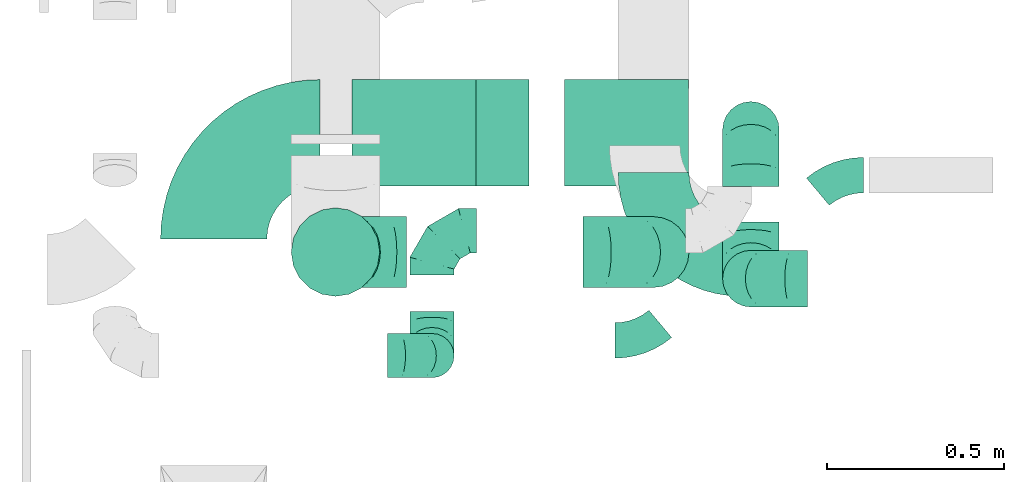
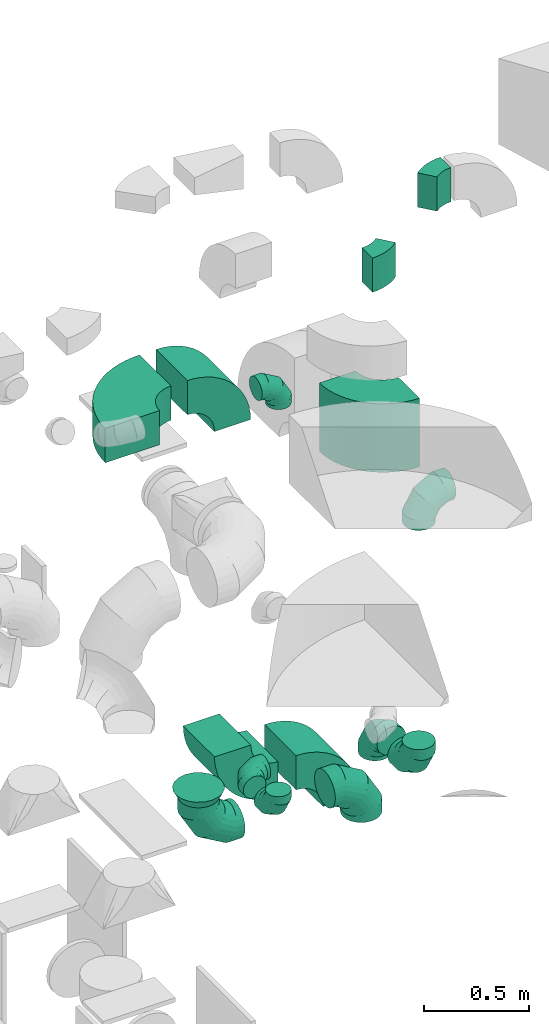
# One storey, part 30 of 59: 16 flow fittings.
"""IFC2X3 building model written with IfcOpenShell, lengths in millimetres."""

from ifc_helpers import new_model, entity, si_unit, converted_unit, derived_unit, direction, frame, frame_2d, origin, place, context, subcontext, project, spatial, polyline, circle_curve, parameter, trimmed, segment, composite_curve, outline, extrude, faceted_brep, source, transform, mapped, material, type_object, type_shapes, element, save


model = new_model("IFC2X3")

# Units and contexts
model_context = context("Model", 3, precision=0.01, world=origin(), true_north=direction((6.12303176911189e-17, 1.0)))
body_context = subcontext(model_context, "Body", "Model", "MODEL_VIEW")
ifc_project = project(units=[si_unit("LENGTHUNIT", "METRE", prefix="MILLI"), si_unit("AREAUNIT", "SQUARE_METRE"), si_unit("VOLUMEUNIT", "CUBIC_METRE"), converted_unit("PLANEANGLEUNIT", "DEGREE", entity("IfcRatioMeasure", 0.0174532925199433), si_unit("PLANEANGLEUNIT", "RADIAN"), dimensions=[0, 0, 0, 0, 0, 0, 0]), si_unit("MASSUNIT", "GRAM", prefix="KILO"), derived_unit("MASSDENSITYUNIT", [(si_unit("MASSUNIT", "GRAM", prefix="KILO"), 1), (si_unit("LENGTHUNIT", "METRE"), -3)]), derived_unit("MOMENTOFINERTIAUNIT", [(si_unit("LENGTHUNIT", "METRE"), 4)]), si_unit("TIMEUNIT", "SECOND"), si_unit("FREQUENCYUNIT", "HERTZ"), si_unit("THERMODYNAMICTEMPERATUREUNIT", "DEGREE_CELSIUS"), derived_unit("THERMALTRANSMITTANCEUNIT", [(si_unit("MASSUNIT", "GRAM", prefix="KILO"), 1), (si_unit("THERMODYNAMICTEMPERATUREUNIT", "KELVIN"), -1), (si_unit("TIMEUNIT", "SECOND"), -3)]), derived_unit("VOLUMETRICFLOWRATEUNIT", [(si_unit("LENGTHUNIT", "METRE"), 3), (si_unit("TIMEUNIT", "SECOND"), -1)]), derived_unit("MASSFLOWRATEUNIT", [(si_unit("MASSUNIT", "GRAM", prefix="KILO"), 1), (si_unit("TIMEUNIT", "SECOND"), -1)]), derived_unit("ROTATIONALFREQUENCYUNIT", [(si_unit("TIMEUNIT", "SECOND"), -1)]), si_unit("ELECTRICCURRENTUNIT", "AMPERE"), si_unit("ELECTRICVOLTAGEUNIT", "VOLT"), si_unit("POWERUNIT", "WATT"), si_unit("FORCEUNIT", "NEWTON", prefix="KILO"), si_unit("ILLUMINANCEUNIT", "LUX"), si_unit("LUMINOUSFLUXUNIT", "LUMEN"), si_unit("LUMINOUSINTENSITYUNIT", "CANDELA"), derived_unit("USERDEFINED", [(si_unit("MASSUNIT", "GRAM", prefix="KILO"), -1), (si_unit("LENGTHUNIT", "METRE"), -2), (si_unit("TIMEUNIT", "SECOND"), 3), (si_unit("LUMINOUSFLUXUNIT", "LUMEN"), 1)]), derived_unit("LINEARVELOCITYUNIT", [(si_unit("LENGTHUNIT", "METRE"), 1), (si_unit("TIMEUNIT", "SECOND"), -1)]), si_unit("PRESSUREUNIT", "PASCAL"), derived_unit("USERDEFINED", [(si_unit("LENGTHUNIT", "METRE"), -2), (si_unit("MASSUNIT", "GRAM", prefix="KILO"), 1), (si_unit("TIMEUNIT", "SECOND"), -2)]), derived_unit("LINEARFORCEUNIT", [(si_unit("MASSUNIT", "GRAM", prefix="KILO"), 1), (si_unit("LENGTHUNIT", "METRE"), 1), (si_unit("TIMEUNIT", "SECOND"), -2), (si_unit("LENGTHUNIT", "METRE"), -1)]), derived_unit("PLANARFORCEUNIT", [(si_unit("MASSUNIT", "GRAM", prefix="KILO"), 1), (si_unit("LENGTHUNIT", "METRE"), 1), (si_unit("TIMEUNIT", "SECOND"), -2), (si_unit("LENGTHUNIT", "METRE"), -2)])], contexts=[model_context])

# Site, building, storey
site_placement = place(None, origin())
site = spatial("IfcSite", under=ifc_project, at=site_placement, CompositionType="ELEMENT")
building_placement = place(site_placement, origin())
building = spatial("IfcBuilding", under=site, at=building_placement, CompositionType="ELEMENT")
storey_placement = place(building_placement, frame((0.0, 0.0, 28200.0)))
storey = spatial("IfcBuildingStorey", under=building, at=storey_placement, CompositionType="ELEMENT", Elevation=28200.0)

# Flow fittings
ifc_material = material()
duct_fitting_type_1 = type_object("IfcDuctFittingType", PredefinedType="NOTDEFINED", material=ifc_material)
shared_shape_1 = source(origin(), body_context, "Body", "Brep", [
    faceted_brep([(-160.0, 0.0, -80.0), (-160.0, -20.71, -77.27), (-160.0, -40.0, -69.28), (-160.0, -56.57, -56.57), (-160.0, -69.28, -40.0), (-160.0, -77.27, -20.71), (-160.0, -80.0, 0.0), (-160.0, -77.27, 20.71), (-160.0, -69.28, 40.0), (-160.0, -56.57, 56.57), (-160.0, -40.0, 69.28), (-160.0, -20.71, 77.27), (-160.0, 0.0, 80.0), (-160.0, 20.71, 77.27), (-160.0, 40.0, 69.28), (-160.0, 56.57, 56.57), (-160.0, 69.28, 40.0), (-160.0, 77.27, 20.71), (-160.0, 80.0, 0.0), (-160.0, 77.27, -20.71), (-160.0, 69.28, -40.0), (-160.0, 56.57, -56.57), (-160.0, 40.0, -69.28), (-160.0, 20.71, -77.27), (-122.68, 20.71, 77.27), (-127.85, 40.0, 69.28), (-117.13, 0.0, 80.0), (-132.29, 56.57, 56.57), (-137.83, 77.27, 20.71), (-138.56, 80.0, 0.0), (-135.69, 69.28, 40.0), (-135.69, 69.28, -40.0), (-132.29, 56.57, -56.57), (-137.83, 77.27, -20.71), (-122.68, 20.71, -77.27), (-117.13, 0.0, -80.0), (-127.85, 40.0, -69.28), (-111.58, -20.71, -77.27), (-106.41, -40.0, -69.28), (-101.97, -56.57, -56.57), (-98.56, -69.28, -40.0), (-96.42, -77.27, -20.71), (-95.69, -80.0, 0.0), (-96.42, -77.27, 20.71), (-98.56, -69.28, 40.0), (-101.97, -56.57, 56.57), (-106.41, -40.0, 69.28), (-111.58, -20.71, 77.27), (-58.03, 58.03, 77.27), (-72.15, 72.15, 69.28), (-42.87, 42.87, 80.0), (-84.28, 84.28, 56.57), (-93.59, 93.59, 40.0), (-99.44, 99.44, 20.71), (-101.44, 101.44, 0.0), (-99.44, 99.44, -20.71), (-93.59, 93.59, -40.0), (-84.28, 84.28, -56.57), (-58.03, 58.03, -77.27), (-42.87, 42.87, -80.0), (-72.15, 72.15, -69.28), (-27.71, 27.71, -77.27), (-13.59, 13.59, -69.28), (-1.46, 1.46, -56.57), (7.85, -7.85, -40.0), (13.7, -13.7, -20.71), (15.69, -15.69, 0.0), (13.7, -13.7, 20.71), (7.85, -7.85, 40.0), (-1.46, 1.46, 56.57), (-13.59, 13.59, 69.28), (-27.71, 27.71, 77.27), (-20.71, 122.68, 77.27), (-40.0, 127.85, 69.28), (0.0, 117.13, 80.0), (-56.57, 132.29, 56.57), (-69.28, 135.69, 40.0), (-77.27, 137.83, 20.71), (-80.0, 138.56, 0.0), (-77.27, 137.83, -20.71), (-69.28, 135.69, -40.0), (-56.57, 132.29, -56.57), (-20.71, 122.68, -77.27), (0.0, 117.13, -80.0), (-40.0, 127.85, -69.28), (20.71, 111.58, -77.27), (40.0, 106.41, -69.28), (56.57, 101.97, -56.57), (69.28, 98.56, -40.0), (77.27, 96.42, -20.71), (80.0, 95.69, 0.0), (77.27, 96.42, 20.71), (69.28, 98.56, 40.0), (56.57, 101.97, 56.57), (40.0, 106.41, 69.28), (20.71, 111.58, 77.27), (-20.71, 160.0, -77.27), (-40.0, 160.0, -69.28), (-56.57, 160.0, -56.57), (-69.28, 160.0, -40.0), (-77.27, 160.0, -20.71), (-80.0, 160.0, 0.0), (-77.27, 160.0, 20.71), (-69.28, 160.0, 40.0), (-56.57, 160.0, 56.57), (-40.0, 160.0, 69.28), (-20.71, 160.0, 77.27), (0.0, 160.0, 80.0), (20.71, 160.0, 77.27), (40.0, 160.0, 69.28), (56.57, 160.0, 56.57), (69.28, 160.0, 40.0), (77.27, 160.0, 20.71), (80.0, 160.0, 0.0), (77.27, 160.0, -20.71), (69.28, 160.0, -40.0), (56.57, 160.0, -56.57), (40.0, 160.0, -69.28), (20.71, 160.0, -77.27), (0.0, 160.0, -80.0)], [[[0, 1, 2, 3, 4, 5, 6, 7, 8, 9, 10, 11, 12, 13, 14, 15, 16, 17, 18, 19, 20, 21, 22, 23]], [[24, 25, 14, 13]], [[26, 24, 13, 12]], [[14, 25, 27, 15]], [[28, 29, 18, 17]], [[30, 28, 17, 16]], [[15, 27, 30, 16]], [[20, 31, 32, 21]], [[33, 31, 20, 19]], [[18, 29, 33, 19]], [[34, 35, 0, 23]], [[36, 34, 23, 22]], [[32, 36, 22, 21]], [[1, 0, 35, 37]], [[2, 1, 37, 38]], [[3, 2, 38, 39]], [[5, 4, 40, 41]], [[6, 5, 41, 42]], [[39, 40, 4, 3]], [[6, 42, 43, 7]], [[7, 43, 44, 8]], [[8, 44, 45, 9]], [[9, 45, 46, 10]], [[10, 46, 47, 11]], [[26, 12, 11, 47]], [[48, 49, 25, 24]], [[50, 48, 24, 26]], [[27, 25, 49, 51]], [[52, 53, 28, 30]], [[51, 52, 30, 27]], [[29, 28, 53, 54]], [[55, 56, 31, 33]], [[54, 55, 33, 29]], [[32, 31, 56, 57]], [[58, 59, 35, 34]], [[60, 58, 34, 36]], [[57, 60, 36, 32]], [[37, 35, 59, 61]], [[38, 37, 61, 62]], [[39, 38, 62, 63]], [[41, 40, 64, 65]], [[42, 41, 65, 66]], [[63, 64, 40, 39]], [[43, 42, 66, 67]], [[44, 43, 67, 68]], [[68, 69, 45, 44]], [[46, 45, 69, 70]], [[47, 46, 70, 71]], [[26, 47, 71, 50]], [[72, 73, 49, 48]], [[74, 72, 48, 50]], [[51, 49, 73, 75]], [[76, 77, 53, 52]], [[75, 76, 52, 51]], [[54, 53, 77, 78]], [[79, 80, 56, 55]], [[78, 79, 55, 54]], [[57, 56, 80, 81]], [[82, 83, 59, 58]], [[84, 82, 58, 60]], [[81, 84, 60, 57]], [[61, 59, 83, 85]], [[62, 61, 85, 86]], [[63, 62, 86, 87]], [[65, 64, 88, 89]], [[66, 65, 89, 90]], [[87, 88, 64, 63]], [[67, 66, 90, 91]], [[68, 67, 91, 92]], [[92, 93, 69, 68]], [[70, 69, 93, 94]], [[71, 70, 94, 95]], [[50, 71, 95, 74]], [[96, 97, 98, 99, 100, 101, 102, 103, 104, 105, 106, 107, 108, 109, 110, 111, 112, 113, 114, 115, 116, 117, 118, 119]], [[72, 74, 107, 106]], [[73, 72, 106, 105]], [[75, 73, 105, 104]], [[77, 76, 103, 102]], [[78, 77, 102, 101]], [[75, 104, 103, 76]], [[78, 101, 100, 79]], [[79, 100, 99, 80]], [[80, 99, 98, 81]], [[84, 97, 96, 82]], [[82, 96, 119, 83]], [[84, 81, 98, 97]], [[118, 117, 86, 85]], [[119, 118, 85, 83]], [[116, 87, 86, 117]], [[88, 115, 114, 89]], [[89, 114, 113, 90]], [[115, 88, 87, 116]], [[112, 111, 92, 91]], [[113, 112, 91, 90]], [[111, 110, 93, 92]], [[95, 94, 109, 108]], [[74, 95, 108, 107]], [[110, 109, 94, 93]]]),
])
type_shapes(duct_fitting_type_1, [shared_shape_1])
for number, where, z_axis, x_axis in (
    (1, (52066.37, 12174.0, 2105.0), (0.0, -1.0, 0.0), (-1.0, 0.0, 0.0)),
    (2, (52066.37, 12174.0, 505.0), (1.0, 0.0, 0.0), (0.0, 0.0, -1.0)),
    (3, (52066.37, 12593.92, 505.0), (-1.0, 0.0, -3.13508483310326e-06), (0.0, 1.0, 0.0)),
):
    element("IfcFlowFitting", number, at=place(storey_placement, frame(where, z_axis=z_axis, x_axis=x_axis)), inside=storey, type_object=duct_fitting_type_1, material=ifc_material, context=body_context, shape_type="MappedRepresentation", body=[
        mapped(shared_shape_1, transform((0.0, 0.0, 0.0), scale=1.0)),
    ])
duct_fitting_type_2 = type_object("IfcDuctFittingType", PredefinedType="NOTDEFINED", material=ifc_material)
shared_shape_2 = source(origin(), body_context, "Body", "Brep", [
    faceted_brep([(-200.0, 0.0, -100.0), (-200.0, -25.88, -96.59), (-200.0, -50.0, -86.6), (-200.0, -70.71, -70.71), (-200.0, -86.6, -50.0), (-200.0, -96.59, -25.88), (-200.0, -100.0, 0.0), (-200.0, -96.59, 25.88), (-200.0, -86.6, 50.0), (-200.0, -70.71, 70.71), (-200.0, -50.0, 86.6), (-200.0, -25.88, 96.59), (-200.0, 0.0, 100.0), (-200.0, 25.88, 96.59), (-200.0, 50.0, 86.6), (-200.0, 70.71, 70.71), (-200.0, 86.6, 50.0), (-200.0, 96.59, 25.88), (-200.0, 100.0, 0.0), (-200.0, 96.59, -25.88), (-200.0, 86.6, -50.0), (-200.0, 70.71, -70.71), (-200.0, 50.0, -86.6), (-200.0, 25.88, -96.59), (-153.35, 25.88, 96.59), (-159.81, 50.0, 86.6), (-146.41, 0.0, 100.0), (-165.36, 70.71, 70.71), (-172.29, 96.59, 25.88), (-173.21, 100.0, 0.0), (-169.62, 86.6, 50.0), (-169.62, 86.6, -50.0), (-165.36, 70.71, -70.71), (-172.29, 96.59, -25.88), (-153.35, 25.88, -96.59), (-146.41, 0.0, -100.0), (-159.81, 50.0, -86.6), (-139.48, -25.88, -96.59), (-133.01, -50.0, -86.6), (-127.46, -70.71, -70.71), (-123.21, -86.6, -50.0), (-120.53, -96.59, -25.88), (-119.62, -100.0, 0.0), (-120.53, -96.59, 25.88), (-123.21, -86.6, 50.0), (-127.46, -70.71, 70.71), (-133.01, -50.0, 86.6), (-139.48, -25.88, 96.59), (-72.54, 72.54, 96.59), (-90.19, 90.19, 86.6), (-53.59, 53.59, 100.0), (-105.35, 105.35, 70.71), (-116.99, 116.99, 50.0), (-124.3, 124.3, 25.88), (-126.79, 126.79, 0.0), (-124.3, 124.3, -25.88), (-116.99, 116.99, -50.0), (-105.35, 105.35, -70.71), (-72.54, 72.54, -96.59), (-53.59, 53.59, -100.0), (-90.19, 90.19, -86.6), (-34.64, 34.64, -96.59), (-16.99, 16.99, -86.6), (-1.83, 1.83, -70.71), (9.81, -9.81, -50.0), (17.12, -17.12, -25.88), (19.62, -19.62, 0.0), (17.12, -17.12, 25.88), (9.81, -9.81, 50.0), (-1.83, 1.83, 70.71), (-16.99, 16.99, 86.6), (-34.64, 34.64, 96.59), (-25.88, 153.35, 96.59), (-50.0, 159.81, 86.6), (0.0, 146.41, 100.0), (-70.71, 165.36, 70.71), (-86.6, 169.62, 50.0), (-96.59, 172.29, 25.88), (-100.0, 173.21, 0.0), (-96.59, 172.29, -25.88), (-86.6, 169.62, -50.0), (-70.71, 165.36, -70.71), (-25.88, 153.35, -96.59), (0.0, 146.41, -100.0), (-50.0, 159.81, -86.6), (25.88, 139.48, -96.59), (50.0, 133.01, -86.6), (70.71, 127.46, -70.71), (86.6, 123.21, -50.0), (96.59, 120.53, -25.88), (100.0, 119.62, 0.0), (96.59, 120.53, 25.88), (86.6, 123.21, 50.0), (70.71, 127.46, 70.71), (50.0, 133.01, 86.6), (25.88, 139.48, 96.59), (-25.88, 200.0, -96.59), (-50.0, 200.0, -86.6), (-70.71, 200.0, -70.71), (-86.6, 200.0, -50.0), (-96.59, 200.0, -25.88), (-100.0, 200.0, 0.0), (-96.59, 200.0, 25.88), (-86.6, 200.0, 50.0), (-70.71, 200.0, 70.71), (-50.0, 200.0, 86.6), (-25.88, 200.0, 96.59), (0.0, 200.0, 100.0), (25.88, 200.0, 96.59), (50.0, 200.0, 86.6), (70.71, 200.0, 70.71), (86.6, 200.0, 50.0), (96.59, 200.0, 25.88), (100.0, 200.0, 0.0), (96.59, 200.0, -25.88), (86.6, 200.0, -50.0), (70.71, 200.0, -70.71), (50.0, 200.0, -86.6), (25.88, 200.0, -96.59), (0.0, 200.0, -100.0)], [[[0, 1, 2, 3, 4, 5, 6, 7, 8, 9, 10, 11, 12, 13, 14, 15, 16, 17, 18, 19, 20, 21, 22, 23]], [[24, 25, 14, 13]], [[26, 24, 13, 12]], [[14, 25, 27, 15]], [[28, 29, 18, 17]], [[30, 28, 17, 16]], [[15, 27, 30, 16]], [[20, 31, 32, 21]], [[33, 31, 20, 19]], [[18, 29, 33, 19]], [[34, 35, 0, 23]], [[36, 34, 23, 22]], [[32, 36, 22, 21]], [[1, 0, 35, 37]], [[2, 1, 37, 38]], [[38, 39, 3, 2]], [[5, 4, 40, 41]], [[6, 5, 41, 42]], [[39, 40, 4, 3]], [[6, 42, 43, 7]], [[7, 43, 44, 8]], [[8, 44, 45, 9]], [[9, 45, 46, 10]], [[10, 46, 47, 11]], [[26, 12, 11, 47]], [[48, 49, 25, 24]], [[50, 48, 24, 26]], [[27, 25, 49, 51]], [[52, 53, 28, 30]], [[51, 52, 30, 27]], [[29, 28, 53, 54]], [[55, 56, 31, 33]], [[54, 55, 33, 29]], [[32, 31, 56, 57]], [[58, 59, 35, 34]], [[60, 58, 34, 36]], [[57, 60, 36, 32]], [[37, 35, 59, 61]], [[38, 37, 61, 62]], [[39, 38, 62, 63]], [[41, 40, 64, 65]], [[42, 41, 65, 66]], [[63, 64, 40, 39]], [[43, 42, 66, 67]], [[44, 43, 67, 68]], [[68, 69, 45, 44]], [[46, 45, 69, 70]], [[47, 46, 70, 71]], [[26, 47, 71, 50]], [[72, 73, 49, 48]], [[74, 72, 48, 50]], [[51, 49, 73, 75]], [[76, 77, 53, 52]], [[75, 76, 52, 51]], [[54, 53, 77, 78]], [[79, 80, 56, 55]], [[78, 79, 55, 54]], [[57, 56, 80, 81]], [[82, 83, 59, 58]], [[84, 82, 58, 60]], [[81, 84, 60, 57]], [[61, 59, 83, 85]], [[62, 61, 85, 86]], [[63, 62, 86, 87]], [[65, 64, 88, 89]], [[66, 65, 89, 90]], [[87, 88, 64, 63]], [[67, 66, 90, 91]], [[68, 67, 91, 92]], [[92, 93, 69, 68]], [[70, 69, 93, 94]], [[71, 70, 94, 95]], [[50, 71, 95, 74]], [[96, 97, 98, 99, 100, 101, 102, 103, 104, 105, 106, 107, 108, 109, 110, 111, 112, 113, 114, 115, 116, 117, 118, 119]], [[72, 74, 107, 106]], [[73, 72, 106, 105]], [[75, 73, 105, 104]], [[102, 101, 78, 77]], [[103, 102, 77, 76]], [[75, 104, 103, 76]], [[78, 101, 100, 79]], [[79, 100, 99, 80]], [[80, 99, 98, 81]], [[84, 97, 96, 82]], [[82, 96, 119, 83]], [[84, 81, 98, 97]], [[118, 117, 86, 85]], [[119, 118, 85, 83]], [[116, 87, 86, 117]], [[88, 115, 114, 89]], [[89, 114, 113, 90]], [[115, 88, 87, 116]], [[91, 90, 113, 112]], [[92, 91, 112, 111]], [[111, 110, 93, 92]], [[95, 94, 109, 108]], [[74, 95, 108, 107]], [[110, 109, 94, 93]]]),
])
type_shapes(duct_fitting_type_2, [shared_shape_2])
for number, where, z_axis, x_axis in (
    (4, (50893.68, 12249.04, 504.33), (0.0, -1.0, 0.0), (0.0, 0.0, -1.0)),
    (5, (51791.72, 12249.04, 504.33), (0.0, 1.0, 0.0), (1.0, 0.0, 0.0)),
):
    element("IfcFlowFitting", number, at=place(storey_placement, frame(where, z_axis=z_axis, x_axis=x_axis)), inside=storey, type_object=duct_fitting_type_2, material=ifc_material, context=body_context, shape_type="MappedRepresentation", body=[
        mapped(shared_shape_2, transform((0.0, 0.0, 0.0), scale=1.0)),
    ])
duct_fitting_type_3 = type_object("IfcDuctFittingType", PredefinedType="NOTDEFINED", material=ifc_material)
shared_shape_3 = source(origin(), body_context, "Body", "Brep", [
    faceted_brep([(-125.0, 0.0, -62.5), (-125.0, -16.18, -60.37), (-125.0, -31.25, -54.13), (-125.0, -44.19, -44.19), (-125.0, -54.13, -31.25), (-125.0, -60.37, -16.18), (-125.0, -62.5, 0.0), (-125.0, -60.37, 16.18), (-125.0, -54.13, 31.25), (-125.0, -44.19, 44.19), (-125.0, -31.25, 54.13), (-125.0, -16.18, 60.37), (-125.0, 0.0, 62.5), (-125.0, 16.18, 60.37), (-125.0, 31.25, 54.13), (-125.0, 44.19, 44.19), (-125.0, 54.13, 31.25), (-125.0, 60.37, 16.18), (-125.0, 62.5, 0.0), (-125.0, 60.37, -16.18), (-125.0, 54.13, -31.25), (-125.0, 44.19, -44.19), (-125.0, 31.25, -54.13), (-125.0, 16.18, -60.37), (-95.84, 16.18, 60.37), (-99.88, 31.25, 54.13), (-91.51, 0.0, 62.5), (-103.35, 44.19, 44.19), (-107.68, 60.37, 16.18), (-108.25, 62.5, 0.0), (-106.01, 54.13, 31.25), (-106.01, 54.13, -31.25), (-103.35, 44.19, -44.19), (-107.68, 60.37, -16.18), (-95.84, 16.18, -60.37), (-91.51, 0.0, -62.5), (-99.88, 31.25, -54.13), (-87.17, -16.18, -60.37), (-83.13, -31.25, -54.13), (-79.66, -44.19, -44.19), (-77.0, -54.13, -31.25), (-75.33, -60.37, -16.18), (-74.76, -62.5, 0.0), (-75.33, -60.37, 16.18), (-77.0, -54.13, 31.25), (-79.66, -44.19, 44.19), (-83.13, -31.25, 54.13), (-87.17, -16.18, 60.37), (-45.34, 45.34, 60.37), (-56.37, 56.37, 54.13), (-33.49, 33.49, 62.5), (-65.85, 65.85, 44.19), (-73.12, 73.12, 31.25), (-77.69, 77.69, 16.18), (-79.25, 79.25, 0.0), (-77.69, 77.69, -16.18), (-73.12, 73.12, -31.25), (-65.85, 65.85, -44.19), (-45.34, 45.34, -60.37), (-33.49, 33.49, -62.5), (-56.37, 56.37, -54.13), (-21.65, 21.65, -60.37), (-10.62, 10.62, -54.13), (-1.14, 1.14, -44.19), (6.13, -6.13, -31.25), (10.7, -10.7, -16.18), (12.26, -12.26, 0.0), (10.7, -10.7, 16.18), (6.13, -6.13, 31.25), (-1.14, 1.14, 44.19), (-10.62, 10.62, 54.13), (-21.65, 21.65, 60.37), (-16.18, 95.84, 60.37), (-31.25, 99.88, 54.13), (0.0, 91.51, 62.5), (-44.19, 103.35, 44.19), (-54.13, 106.01, 31.25), (-60.37, 107.68, 16.18), (-62.5, 108.25, 0.0), (-60.37, 107.68, -16.18), (-54.13, 106.01, -31.25), (-44.19, 103.35, -44.19), (-16.18, 95.84, -60.37), (0.0, 91.51, -62.5), (-31.25, 99.88, -54.13), (16.18, 87.17, -60.37), (31.25, 83.13, -54.13), (44.19, 79.66, -44.19), (54.13, 77.0, -31.25), (60.37, 75.33, -16.18), (62.5, 74.76, 0.0), (60.37, 75.33, 16.18), (54.13, 77.0, 31.25), (44.19, 79.66, 44.19), (31.25, 83.13, 54.13), (16.18, 87.17, 60.37), (-16.18, 125.0, -60.37), (-31.25, 125.0, -54.13), (-44.19, 125.0, -44.19), (-54.13, 125.0, -31.25), (-60.37, 125.0, -16.18), (-62.5, 125.0, 0.0), (-60.37, 125.0, 16.18), (-54.13, 125.0, 31.25), (-44.19, 125.0, 44.19), (-31.25, 125.0, 54.13), (-16.18, 125.0, 60.37), (0.0, 125.0, 62.5), (16.18, 125.0, 60.37), (31.25, 125.0, 54.13), (44.19, 125.0, 44.19), (54.13, 125.0, 31.25), (60.37, 125.0, 16.18), (62.5, 125.0, 0.0), (60.37, 125.0, -16.18), (54.13, 125.0, -31.25), (44.19, 125.0, -44.19), (31.25, 125.0, -54.13), (16.18, 125.0, -60.37), (0.0, 125.0, -62.5)], [[[0, 1, 2, 3, 4, 5, 6, 7, 8, 9, 10, 11, 12, 13, 14, 15, 16, 17, 18, 19, 20, 21, 22, 23]], [[24, 25, 14, 13]], [[26, 24, 13, 12]], [[14, 25, 27, 15]], [[28, 29, 18, 17]], [[30, 28, 17, 16]], [[15, 27, 30, 16]], [[20, 31, 32, 21]], [[33, 31, 20, 19]], [[18, 29, 33, 19]], [[34, 35, 0, 23]], [[36, 34, 23, 22]], [[21, 32, 36, 22]], [[1, 0, 35, 37]], [[2, 1, 37, 38]], [[38, 39, 3, 2]], [[5, 4, 40, 41]], [[6, 5, 41, 42]], [[39, 40, 4, 3]], [[6, 42, 43, 7]], [[7, 43, 44, 8]], [[45, 9, 8, 44]], [[9, 45, 46, 10]], [[10, 46, 47, 11]], [[26, 12, 11, 47]], [[48, 49, 25, 24]], [[50, 48, 24, 26]], [[27, 25, 49, 51]], [[52, 53, 28, 30]], [[51, 52, 30, 27]], [[29, 28, 53, 54]], [[55, 56, 31, 33]], [[54, 55, 33, 29]], [[57, 32, 31, 56]], [[58, 59, 35, 34]], [[60, 58, 34, 36]], [[57, 60, 36, 32]], [[37, 35, 59, 61]], [[38, 37, 61, 62]], [[39, 38, 62, 63]], [[41, 40, 64, 65]], [[42, 41, 65, 66]], [[63, 64, 40, 39]], [[43, 42, 66, 67]], [[44, 43, 67, 68]], [[68, 69, 45, 44]], [[46, 45, 69, 70]], [[47, 46, 70, 71]], [[26, 47, 71, 50]], [[72, 73, 49, 48]], [[74, 72, 48, 50]], [[51, 49, 73, 75]], [[76, 77, 53, 52]], [[75, 76, 52, 51]], [[54, 53, 77, 78]], [[79, 80, 56, 55]], [[78, 79, 55, 54]], [[81, 57, 56, 80]], [[82, 83, 59, 58]], [[84, 82, 58, 60]], [[81, 84, 60, 57]], [[61, 59, 83, 85]], [[62, 61, 85, 86]], [[63, 62, 86, 87]], [[65, 64, 88, 89]], [[66, 65, 89, 90]], [[87, 88, 64, 63]], [[67, 66, 90, 91]], [[68, 67, 91, 92]], [[92, 93, 69, 68]], [[70, 69, 93, 94]], [[71, 70, 94, 95]], [[50, 71, 95, 74]], [[96, 97, 98, 99, 100, 101, 102, 103, 104, 105, 106, 107, 108, 109, 110, 111, 112, 113, 114, 115, 116, 117, 118, 119]], [[72, 74, 107, 106]], [[73, 72, 106, 105]], [[75, 73, 105, 104]], [[77, 76, 103, 102]], [[78, 77, 102, 101]], [[75, 104, 103, 76]], [[78, 101, 100, 79]], [[79, 100, 99, 80]], [[80, 99, 98, 81]], [[96, 119, 83, 82]], [[97, 96, 82, 84]], [[84, 81, 98, 97]], [[83, 119, 118, 85]], [[85, 118, 117, 86]], [[116, 87, 86, 117]], [[88, 115, 114, 89]], [[89, 114, 113, 90]], [[115, 88, 87, 116]], [[91, 90, 113, 112]], [[92, 91, 112, 111]], [[111, 110, 93, 92]], [[95, 94, 109, 108]], [[74, 95, 108, 107]], [[110, 109, 94, 93]]]),
])
type_shapes(duct_fitting_type_3, [shared_shape_3])
for number, where, z_axis, x_axis in (
    (6, (51166.02, 12309.22, 700.0), (0.0, 0.0, 1.0), (-1.0, 0.0, 0.0)),
    (7, (51166.02, 11956.82, 700.0), (-1.0, 0.0, 0.0), (0.0, -1.0, 0.0)),
    (8, (51166.02, 11956.82, 3210.0), (0.0, -1.0, 0.0), (0.0, 0.0, 1.0)),
):
    element("IfcFlowFitting", number, at=place(storey_placement, frame(where, z_axis=z_axis, x_axis=x_axis)), inside=storey, type_object=duct_fitting_type_3, material=ifc_material, context=body_context, shape_type="MappedRepresentation", body=[
        mapped(shared_shape_3, transform((0.0, 0.0, 0.0), scale=1.0)),
    ])
duct_fitting_type_4 = type_object("IfcDuctFittingType", PredefinedType="NOTDEFINED", material=ifc_material)
shared_shape_4 = source(origin(), body_context, "Body", "Brep", [
    faceted_brep([(50.0, 80.9, -58.78), (50.0, 95.11, -30.9), (50.0, 100.0, 0.0), (50.0, 95.11, 30.9), (50.0, 80.9, 58.78), (50.0, 58.78, 80.9), (50.0, 30.9, 95.11), (50.0, 0.0, 100.0), (50.0, -30.9, 95.11), (50.0, -58.78, 80.9), (50.0, -80.9, 58.78), (50.0, -95.11, 30.9), (50.0, -100.0, 0.0), (50.0, -95.11, -30.9), (50.0, -80.9, -58.78), (50.0, -58.78, -80.9), (50.0, -30.9, -95.11), (50.0, 0.0, -100.0), (50.0, 30.9, -95.11), (50.0, 58.78, -80.9), (0.0, -125.0, 0.0), (0.0, -118.88, 38.63), (0.0, -101.13, 73.47), (0.0, -73.47, 101.13), (0.0, -38.63, 118.88), (0.0, 0.0, 125.0), (0.0, 38.63, 118.88), (0.0, 73.47, 101.13), (0.0, 101.13, 73.47), (0.0, 118.88, 38.63), (0.0, 125.0, 0.0), (0.0, 118.88, -38.63), (0.0, 101.13, -73.47), (0.0, 73.47, -101.13), (0.0, 38.63, -118.88), (0.0, 0.0, -125.0), (0.0, -38.63, -118.88), (0.0, -73.47, -101.13), (0.0, -101.13, -73.47), (0.0, -118.88, -38.63)], [[[0, 1, 2, 3, 4, 5, 6, 7, 8, 9, 10, 11, 12, 13, 14, 15, 16, 17, 18, 19]], [[20, 21, 22, 23, 24, 25, 26, 27, 28, 29, 30, 31, 32, 33, 34, 35, 36, 37, 38, 39]], [[26, 25, 7, 6]], [[27, 26, 6, 5]], [[5, 4, 28, 27]], [[3, 2, 30, 29]], [[4, 3, 29, 28]], [[21, 20, 12, 11]], [[22, 21, 11, 10]], [[10, 9, 23, 22]], [[8, 7, 25, 24]], [[9, 8, 24, 23]], [[36, 35, 17, 16]], [[37, 36, 16, 15]], [[15, 14, 38, 37]], [[13, 12, 20, 39]], [[14, 13, 39, 38]], [[31, 30, 2, 1]], [[32, 31, 1, 0]], [[0, 19, 33, 32]], [[18, 17, 35, 34]], [[19, 18, 34, 33]]]),
])
type_shapes(duct_fitting_type_4, [shared_shape_4])
flow_fitting_1_placement = place(storey_placement, frame((50893.68, 12249.04, 754.33), z_axis=(0.0, -1.0, 0.0), x_axis=(0.0, 0.0, -1.0)))
element("IfcFlowFitting", 9, at=flow_fitting_1_placement, inside=storey, type_object=duct_fitting_type_4, material=ifc_material, context=body_context, shape_type="MappedRepresentation", body=[
    mapped(shared_shape_4, transform((0.0, 0.0, 0.0), scale=1.0)),
])
duct_fitting_type_5 = type_object("IfcDuctFittingType", PredefinedType="NOTDEFINED", material=ifc_material)
shared_shape_5 = source(origin(), body_context, "Body", "SweptSolid", [
    extrude(outline(composite_curve([segment(polyline([(-300.0, -150.0), (0.0, -150.0)]), True, "CONTINUOUS"), segment(trimmed(circle_curve(frame_2d((150.0, -150.0), x_axis=(0.0, 1.0)), 150.0), [parameter(0.0)], [parameter(90.0)], True, "PARAMETER"), False, "CONTINUOUS"), segment(polyline([(150.0, 0.0), (150.0, 300.0)]), True, "CONTINUOUS"), segment(trimmed(circle_curve(frame_2d((150.0, -150.0), x_axis=(0.0, 1.0)), 450.0), [parameter(0.0)], [parameter(90.0000000000001)], True, "PARAMETER"), True, "CONTINUOUS")], self_intersect=False)), frame((-150.0, 150.0, -100.0), z_axis=(0.0, 0.0, 1.0), x_axis=(-1.0, 0.0, 0.0)), (0.0, 0.0, 1.0), 200.0),
])
type_shapes(duct_fitting_type_5, [shared_shape_5])
flow_fitting_2_placement = place(storey_placement, frame((50549.86, 12585.89, 2900.0), z_axis=(0.0, 0.0, 1.0), x_axis=(-1.0, 0.0, 0.0)))
element("IfcFlowFitting", 10, at=flow_fitting_2_placement, inside=storey, type_object=duct_fitting_type_5, material=ifc_material, context=body_context, shape_type="MappedRepresentation", body=[
    mapped(shared_shape_5, transform((0.0, 0.0, 0.0), scale=1.0)),
])
duct_fitting_type_6 = type_object("IfcDuctFittingType", PredefinedType="NOTDEFINED", material=ifc_material)
shared_shape_6 = source(origin(), body_context, "Body", "SweptSolid", [
    extrude(outline(composite_curve([segment(polyline([(-225.0, -125.0), (-25.0, -125.0)]), True, "CONTINUOUS"), segment(trimmed(circle_curve(frame_2d((125.0, -125.0), x_axis=(0.0, 1.0)), 150.0), [parameter(0.0)], [parameter(90.0)], True, "PARAMETER"), False, "CONTINUOUS"), segment(polyline([(125.0, 25.0), (125.0, 225.0)]), True, "CONTINUOUS"), segment(trimmed(circle_curve(frame_2d((125.0, -125.0), x_axis=(0.0, 1.0)), 350.0), [parameter(0.0)], [parameter(90.0)], True, "PARAMETER"), True, "CONTINUOUS")], self_intersect=False)), frame((-125.0, 125.0, -150.0), z_axis=(0.0, 0.0, 1.0), x_axis=(-1.0, 0.0, 0.0)), (0.0, 0.0, 1.0), 300.0),
])
type_shapes(duct_fitting_type_6, [shared_shape_6])
for number, where, z_axis, x_axis in (
    (11, (51189.86, 12585.89, 2900.0), (0.0, 1.0, 0.0), (1.0, 0.0, 0.0)),
    (12, (51189.86, 12585.89, 500.0), (0.0, -1.0, 0.0), (0.0, 0.0, -1.0)),
    (13, (51789.86, 12585.89, 500.0), (0.0, 1.0, 1.70108211606414e-05), (1.0, 0.0, 0.0)),
):
    element("IfcFlowFitting", number, at=place(storey_placement, frame(where, z_axis=z_axis, x_axis=x_axis)), inside=storey, type_object=duct_fitting_type_6, material=ifc_material, context=body_context, shape_type="MappedRepresentation", body=[
        mapped(shared_shape_6, transform((0.0, 0.0, 0.0), scale=1.0)),
    ])
duct_fitting_type_7 = type_object("IfcDuctFittingType", PredefinedType="NOTDEFINED", material=ifc_material)
shared_shape_7 = source(origin(), body_context, "Body", "SweptSolid", [
    extrude(outline(composite_curve([segment(polyline([(-225.0, -125.0), (-25.0, -125.0)]), True, "CONTINUOUS"), segment(trimmed(circle_curve(frame_2d((125.0, -125.0), x_axis=(0.0, 1.0)), 150.0), [parameter(0.0)], [parameter(90.0000000000001)], True, "PARAMETER"), False, "CONTINUOUS"), segment(polyline([(125.0, 25.0), (125.0, 225.0)]), True, "CONTINUOUS"), segment(trimmed(circle_curve(frame_2d((125.0, -125.0), x_axis=(0.0, 1.0)), 350.0), [parameter(0.0)], [parameter(90.0000000000001)], True, "PARAMETER"), True, "CONTINUOUS")], self_intersect=False)), frame((-125.0, 125.0, -200.0), z_axis=(0.0, 0.0, 1.0), x_axis=(-1.0, 0.0, 0.0)), (0.0, 0.0, 1.0), 400.0),
])
type_shapes(duct_fitting_type_7, [shared_shape_7])
flow_fitting_3_placement = place(storey_placement, frame((51791.36, 12224.0, 2500.0), z_axis=(0.0, 0.0, 1.0), x_axis=(0.0, -1.0, 0.0)))
element("IfcFlowFitting", 14, at=flow_fitting_3_placement, inside=storey, type_object=duct_fitting_type_7, material=ifc_material, context=body_context, shape_type="MappedRepresentation", body=[
    mapped(shared_shape_7, transform((0.0, 0.0, 0.0), scale=1.0)),
])
duct_fitting_type_8 = type_object("IfcDuctFittingType", PredefinedType="NOTDEFINED", material=ifc_material)
shared_shape_8 = source(origin(), body_context, "Body", "SweptSolid", [
    extrude(outline(composite_curve([segment(polyline([(-73.4, -64.28), (26.6, -64.28)]), True, "CONTINUOUS"), segment(trimmed(circle_curve(frame_2d((176.6, -64.28), x_axis=(-0.766044443118975, 0.64278760968654)), 150.0), [parameter(0.0)], [parameter(40.0000000000001)], True, "PARAMETER"), False, "CONTINUOUS"), segment(polyline([(61.7, 32.14), (-14.91, 96.42)]), True, "CONTINUOUS"), segment(trimmed(circle_curve(frame_2d((176.6, -64.28), x_axis=(-0.766044443118975, 0.64278760968654)), 250.0), [parameter(0.0)], [parameter(40.0000000000001)], True, "PARAMETER"), True, "CONTINUOUS")], self_intersect=False)), frame((-8.52, 23.4, -100.0), z_axis=(0.0, 0.0, 1.0), x_axis=(-0.642787609686541, 0.766044443118977, 0.0)), (0.0, 0.0, 1.0), 200.0),
])
type_shapes(duct_fitting_type_8, [shared_shape_8])
flow_fitting_4_placement = place(storey_placement, frame((51754.86, 11999.48, 3650.0)))
element("IfcFlowFitting", 15, at=flow_fitting_4_placement, inside=storey, type_object=duct_fitting_type_8, material=ifc_material, context=body_context, shape_type="MappedRepresentation", body=[
    mapped(shared_shape_8, transform((0.0, 0.0, 0.0), scale=1.0)),
])
flow_fitting_5_placement = place(storey_placement, frame((52311.21, 12466.31, 3650.0), z_axis=(0.0, 0.0, 1.0), x_axis=(-1.0, 0.0, 0.0)))
element("IfcFlowFitting", 16, at=flow_fitting_5_placement, inside=storey, type_object=duct_fitting_type_8, material=ifc_material, context=body_context, shape_type="MappedRepresentation", body=[
    mapped(shared_shape_8, transform((0.0, 0.0, 0.0), scale=1.0)),
])

save(model, "model.ifc")
